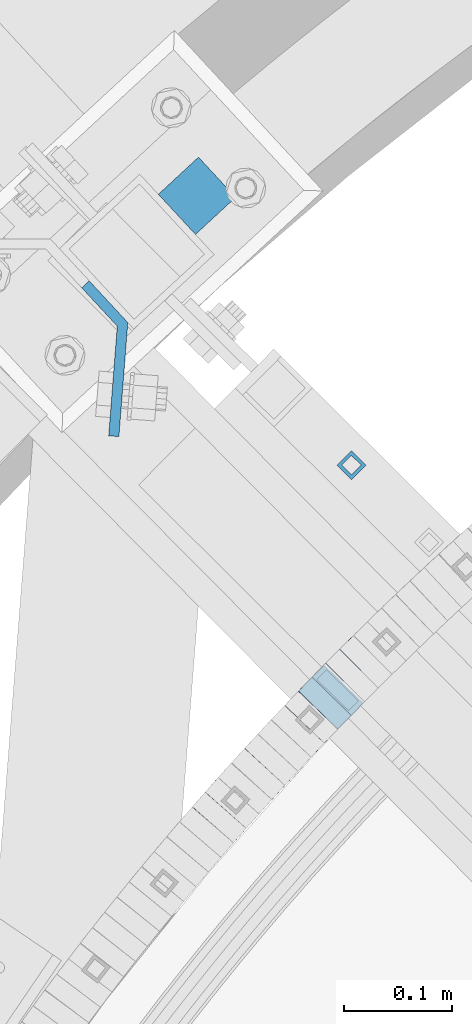
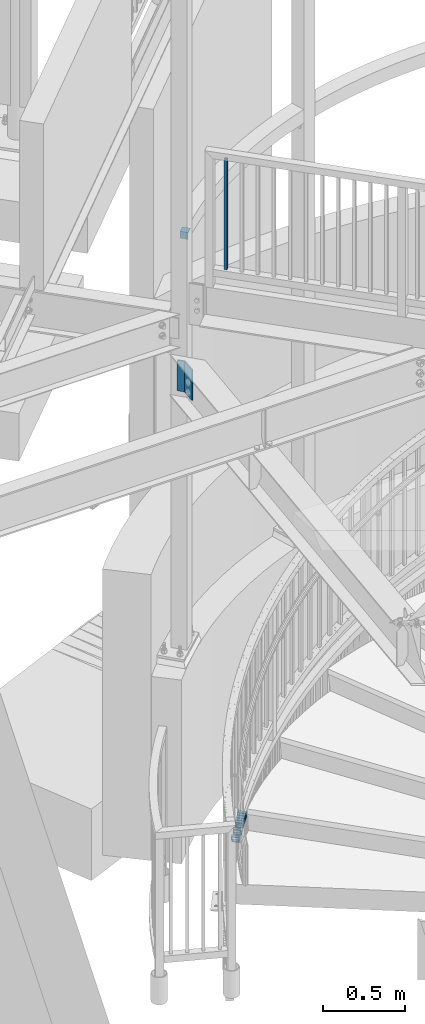
# One storey, part 484 of 975: 10 beams.
"""IFC2X3 building model written with IfcOpenShell, lengths in millimetres."""

from ifc_helpers import new_model, si_unit, frame, origin_with_axes, place, context, subcontext, project, spatial, faceted_brep, material, type_object, element, save


model = new_model("IFC2X3")

# Units and contexts
model_context = context("Model", 3, precision=1e-05, world=origin_with_axes())
body_context = subcontext(model_context, "Body", "Model", "MODEL_VIEW")
ifc_project = project(units=[si_unit("LENGTHUNIT", "METRE", prefix="MILLI"), si_unit("AREAUNIT", "SQUARE_METRE"), si_unit("VOLUMEUNIT", "CUBIC_METRE"), si_unit("MASSUNIT", "GRAM", prefix="KILO"), si_unit("TIMEUNIT", "SECOND"), si_unit("PLANEANGLEUNIT", "RADIAN"), si_unit("SOLIDANGLEUNIT", "STERADIAN"), si_unit("THERMODYNAMICTEMPERATUREUNIT", "DEGREE_CELSIUS"), si_unit("LUMINOUSINTENSITYUNIT", "LUMEN")], contexts=[model_context])

# Site, building, storey
site_placement = place(None, origin_with_axes())
site = spatial("IfcSite", under=ifc_project, at=site_placement, CompositionType="ELEMENT")
building_placement = place(site_placement, origin_with_axes())
building = spatial("IfcBuilding", under=site, at=building_placement, Name="Undefined", CompositionType="ELEMENT")
storey_placement = place(building_placement, origin_with_axes())
storey = spatial("IfcBuildingStorey", under=building, at=storey_placement, Name="Undefined", CompositionType="ELEMENT", Elevation=0.0)

# Beams
ifc_material_1 = material()
beam_type_1 = type_object("IfcBeamType", Name="HSS3/4X3/4X.120_TUBES", PredefinedType="NOTDEFINED")
beam_1_placement = place(storey_placement, frame((32697.1414004107, 5621.60406811201, 4279.9), z_axis=(-0.708992011834517, 0.705216510835392, 0.0), x_axis=(0.0, 0.0, 1.0)))
element("IfcBeam", 1, at=beam_1_placement, inside=storey, type_object=beam_type_1, material=ifc_material_1, Name="PICKET", ObjectType="HSS3/4X3/4X.120_TUBES", context=body_context, shape_type="Brep", body=[
    faceted_brep([(0.0, 6.34999999998763, -6.34999999998763), (0.0, -6.35000000000582, -6.34999999998763), (825.49997943247, -6.35000000000582, -6.34999999998763), (825.49997943247, 6.34999999998763, -6.34999999998763), (0.0, -6.34999999998763, 6.34999999998763), (825.49997943247, -6.34999999998763, 6.34999999998763), (0.0, 6.35000000000946, 6.34999999998763), (825.49997943247, 6.35000000000946, 6.34999999998763), (0.0, 9.52499999997963, -9.52499999997963), (0.0, 9.52500000000873, 9.5249999999869), (825.49997943247, 9.52500000000873, 9.5249999999869), (825.49997943247, 9.52499999997963, -9.52499999997963), (0.0, -9.52499999997963, 9.52499999998327), (825.49997943247, -9.52499999997963, 9.52499999998327), (0.0, -9.52500000000873, -9.5249999999869), (825.49997943247, -9.52500000000873, -9.5249999999869)], [[[0, 1, 2, 3]], [[1, 4, 5, 2]], [[4, 6, 7, 5]], [[6, 0, 3, 7]], [[8, 9, 10, 11]], [[9, 12, 13, 10]], [[12, 14, 15, 13]], [[14, 8, 11, 15]], [[13, 15, 11, 10], [5, 7, 3, 2]], [[14, 12, 9, 8], [6, 4, 1, 0]]]),
])
beam_type_2 = type_object("IfcBeamType", Name="HSS2X2X.188_TUBES", PredefinedType="NOTDEFINED")
beam_2_placement = place(storey_placement, frame((32709.6480122924, 5438.25102614261, 325.589963452377), z_axis=(0.707106781186513, -0.707106781186582, 3.1377567211166e-14), x_axis=(-0.673979567924122, -0.673979567924025, -0.302494766965906)))
element("IfcBeam", 2, at=beam_2_placement, inside=storey, type_object=beam_type_2, material=ifc_material_1, Name="WALL", ObjectType="HSS2X2X.188_TUBES", context=body_context, shape_type="Brep", body=[
    faceted_brep([(0.0, 20.6374999999753, -20.6375000000298), (0.0, -20.6375000000153, -20.6375000000153), (18.8433011969464, -20.6374999999898, -20.6375000000226), (18.8433011969719, 20.6375000000007, -20.6374999999862), (0.0, -20.6374999999825, 20.6375000000335), (18.8433011969828, -20.6375000000044, 20.6375000000189), (0.0, 20.6375000000116, 20.6375000000189), (18.8433011970155, 20.6374999999862, 20.6375000000517), (0.0, 25.3999999999724, -25.4000000000342), (0.0, 25.400000000016, 25.4000000000196), (18.8433011970228, 25.3999999999833, 25.4000000000597), (18.8433011969719, 25.4000000000015, -25.3999999999869), (0.0, -25.399999999976, 25.4000000000378), (18.8433011969864, -25.4000000000051, 25.4000000000196), (0.0, -25.400000000016, -25.4000000000196), (18.8433011969391, -25.3999999999869, -25.4000000000269)], [[[0, 1, 2, 3]], [[1, 4, 5, 2]], [[4, 6, 7, 5]], [[6, 0, 3, 7]], [[8, 9, 10, 11]], [[9, 12, 13, 10]], [[12, 14, 15, 13]], [[14, 8, 11, 15]], [[13, 15, 11, 10], [5, 7, 3, 2]], [[14, 12, 9, 8], [6, 4, 1, 0]]]),
])
beam_3_placement = place(storey_placement, frame((32696.6904416924, 5425.42022046742, 319.898575306206), z_axis=(0.715441150794838, -0.698672999155798, -8.11802465250365e-11), x_axis=(-0.665704015149498, -0.681680911153189, -0.303561031068211)))
element("IfcBeam", 3, at=beam_3_placement, inside=storey, type_object=beam_type_2, material=ifc_material_1, Name="WALL", ObjectType="HSS2X2X.188_TUBES", context=body_context, shape_type="Brep", body=[
    faceted_brep([(0.0, 20.6374999999753, -20.6375000000298), (0.0, -20.6375000000153, -20.6375000000153), (18.7771137292038, -20.637500000008, -20.6374999999862), (18.777113729182, 20.6375000000062, -20.6375000000189), (0.0, -20.6374999999825, 20.6375000000335), (18.7771137291729, -20.6374999999916, 20.6374999999753), (0.0, 20.6375000000116, 20.6375000000189), (18.7771137291529, 20.6375000000207, 20.6374999999389), (0.0, 25.3999999999724, -25.4000000000342), (0.0, 25.400000000016, 25.4000000000196), (18.7771137291475, 25.4000000000251, 25.3999999999287), (18.7771137291857, 25.4000000000051, -25.4000000000196), (0.0, -25.399999999976, 25.4000000000378), (18.7771137291711, -25.3999999999905, 25.3999999999724), (0.0, -25.400000000016, -25.4000000000196), (18.7771137292129, -25.4000000000124, -25.3999999999724)], [[[0, 1, 2, 3]], [[1, 4, 5, 2]], [[4, 6, 7, 5]], [[6, 0, 3, 7]], [[8, 9, 10, 11]], [[9, 12, 13, 10]], [[12, 14, 15, 13]], [[14, 8, 11, 15]], [[13, 15, 11, 10], [5, 7, 3, 2]], [[14, 12, 9, 8], [6, 4, 1, 0]]]),
])
beam_4_placement = place(storey_placement, frame((32684.2760341581, 5412.70786715233, 314.2379475618), z_axis=(0.715441150794838, -0.698672999155798, -8.11802465250365e-11), x_axis=(-0.664621009862544, -0.680571913859332, -0.308384148936255)))
element("IfcBeam", 4, at=beam_4_placement, inside=storey, type_object=beam_type_2, material=ifc_material_1, Name="WALL", ObjectType="HSS2X2X.188_TUBES", context=body_context, shape_type="Brep", body=[
    faceted_brep([(0.0, 20.6374999999753, -20.6375000000298), (0.0, -20.6375000000153, -20.6375000000153), (18.8066477608099, -20.6374999999862, -20.6375000000116), (18.8066477608172, 20.6375000000062, -20.6374999999971), (0.0, -20.6374999999825, 20.6375000000335), (18.8066477608463, -20.6375000000062, 20.6375000000407), (0.0, 20.6375000000116, 20.6375000000189), (18.8066477608536, 20.6374999999844, 20.637500000048), (0.0, 25.3999999999724, -25.4000000000342), (0.0, 25.400000000016, 25.4000000000196), (18.8066477608591, 25.3999999999814, 25.400000000056), (18.8066477608154, 25.4000000000051, -25.4000000000015), (0.0, -25.399999999976, 25.4000000000378), (18.8066477608518, -25.4000000000087, 25.4000000000451), (0.0, -25.400000000016, -25.4000000000196), (18.8066477608081, -25.3999999999851, -25.4000000000196)], [[[0, 1, 2, 3]], [[1, 4, 5, 2]], [[4, 6, 7, 5]], [[6, 0, 3, 7]], [[8, 9, 10, 11]], [[9, 12, 13, 10]], [[12, 14, 15, 13]], [[14, 8, 11, 15]], [[13, 15, 11, 10], [5, 7, 3, 2]], [[14, 12, 9, 8], [6, 4, 1, 0]]]),
])
beam_5_placement = place(storey_placement, frame((32671.3977147235, 5399.64724950157, 308.389345705644), z_axis=(0.723608232244992, -0.690210928794435, 1.00843806194462e-10), x_axis=(-0.657892055054821, -0.689725542057486, -0.302418122025204)))
element("IfcBeam", 5, at=beam_5_placement, inside=storey, type_object=beam_type_2, material=ifc_material_1, Name="WALL", ObjectType="HSS2X2X.188_TUBES", context=body_context, shape_type="Brep", body=[
    faceted_brep([(0.0, 20.6374999999753, -20.6375000000298), (0.0, -20.6375000000153, -20.6375000000153), (18.8480768248774, -20.6374999999716, -20.6375000000735), (18.8480768249356, 20.6375000000153, -20.6375000000226), (0.0, -20.6374999999825, 20.6375000000335), (18.8480768249283, -20.6374999999935, 20.6374999999716), (0.0, 20.6375000000116, 20.6375000000189), (18.8480768249865, 20.6374999999935, 20.6375000000262), (0.0, 25.3999999999724, -25.4000000000342), (0.0, 25.400000000016, 25.4000000000196), (18.848076825001, 25.3999999999887, 25.4000000000378), (18.8480768249392, 25.4000000000142, -25.4000000000233), (0.0, -25.399999999976, 25.4000000000378), (18.8480768249283, -25.399999999996, 25.3999999999833), (0.0, -25.400000000016, -25.4000000000196), (18.8480768248664, -25.3999999999687, -25.4000000000779)], [[[0, 1, 2, 3]], [[1, 4, 5, 2]], [[4, 6, 7, 5]], [[6, 0, 3, 7]], [[8, 9, 10, 11]], [[9, 12, 13, 10]], [[12, 14, 15, 13]], [[14, 8, 11, 15]], [[13, 15, 11, 10], [5, 7, 3, 2]], [[14, 12, 9, 8], [6, 4, 1, 0]]]),
])
beam_6_placement = place(storey_placement, frame((32659.0070910159, 5386.70265124124, 302.737230108235), z_axis=(0.726393020279012, -0.687279550175862, 2.07463699553046e-11), x_axis=(-0.653802268984227, -0.691010527983261, -0.308297004992542)))
element("IfcBeam", 6, at=beam_6_placement, inside=storey, type_object=beam_type_2, material=ifc_material_1, Name="WALL", ObjectType="HSS2X2X.188_TUBES", context=body_context, shape_type="Brep", body=[
    faceted_brep([(0.0, 20.6374999999753, -20.6375000000298), (0.0, -20.6375000000153, -20.6375000000153), (18.8066477608099, -20.6374999999862, -20.6375000000116), (18.8066477608172, 20.6375000000062, -20.6374999999971), (0.0, -20.6374999999825, 20.6375000000335), (18.8066477608463, -20.6375000000062, 20.6375000000407), (0.0, 20.6375000000116, 20.6375000000189), (18.8066477608536, 20.6374999999844, 20.637500000048), (0.0, 25.3999999999724, -25.4000000000342), (0.0, 25.400000000016, 25.4000000000196), (18.8066477608591, 25.3999999999814, 25.400000000056), (18.8066477608154, 25.4000000000051, -25.4000000000015), (0.0, -25.399999999976, 25.4000000000378), (18.8066477608518, -25.4000000000087, 25.4000000000451), (0.0, -25.400000000016, -25.4000000000196), (18.8066477608081, -25.3999999999851, -25.4000000000196)], [[[0, 1, 2, 3]], [[1, 4, 5, 2]], [[4, 6, 7, 5]], [[6, 0, 3, 7]], [[8, 9, 10, 11]], [[9, 12, 13, 10]], [[12, 14, 15, 13]], [[14, 8, 11, 15]], [[13, 15, 11, 10], [5, 7, 3, 2]], [[14, 12, 9, 8], [6, 4, 1, 0]]]),
])
beam_7_placement = place(storey_placement, frame((32622.0405859042, 5347.29049031292, 285.535940786572), z_axis=(0.737154140605314, -0.675724628075994, 3.47016168689151e-10), x_axis=(-0.642844486019819, -0.701284894021664, -0.308140332009522)))
element("IfcBeam", 7, at=beam_7_placement, inside=storey, type_object=beam_type_2, material=ifc_material_1, Name="WALL", ObjectType="HSS2X2X.188_TUBES", context=body_context, shape_type="Brep", body=[
    faceted_brep([(0.0, 20.6374999999753, -20.6375000000298), (0.0, -20.6375000000153, -20.6375000000153), (18.8225928075335, -20.6374999999935, -20.6375000000298), (18.8225928075699, 20.6374999999898, -20.6374999999825), (0.0, -20.6374999999825, 20.6375000000335), (18.8225928075772, -20.637500000008, 20.6375000000226), (0.0, 20.6375000000116, 20.6375000000189), (18.8225928076135, 20.6374999999753, 20.6375000000698), (0.0, 25.3999999999724, -25.4000000000342), (0.0, 25.400000000016, 25.4000000000196), (18.8225928076281, 25.3999999999705, 25.4000000000815), (18.8225928075663, 25.3999999999905, -25.3999999999796), (0.0, -25.399999999976, 25.4000000000378), (18.8225928075808, -25.4000000000087, 25.4000000000233), (0.0, -25.400000000016, -25.4000000000196), (18.8225928075226, -25.3999999999905, -25.4000000000378)], [[[0, 1, 2, 3]], [[1, 4, 5, 2]], [[4, 6, 7, 5]], [[6, 0, 3, 7]], [[8, 9, 10, 11]], [[9, 12, 13, 10]], [[12, 14, 15, 13]], [[14, 8, 11, 15]], [[13, 15, 11, 10], [5, 7, 3, 2]], [[14, 12, 9, 8], [6, 4, 1, 0]]]),
])
beam_8_placement = place(storey_placement, frame((32585.5961167132, 5307.15950885067, 268.332942800624), z_axis=(0.752922081455558, -0.658109671146557, 6.12868120697384e-11), x_axis=(-0.626164333835291, -0.716374449811682, -0.307775688919083)))
element("IfcBeam", 8, at=beam_8_placement, inside=storey, type_object=beam_type_2, material=ifc_material_1, Name="WALL", ObjectType="HSS2X2X.188_TUBES", context=body_context, shape_type="Brep", body=[
    faceted_brep([(0.0, 20.6374999999753, -20.6375000000298), (0.0, -20.6375000000153, -20.6375000000153), (18.8433011969464, -20.6374999999898, -20.6375000000226), (18.8433011969719, 20.6375000000007, -20.6374999999862), (0.0, -20.6374999999825, 20.6375000000335), (18.8433011969828, -20.6375000000044, 20.6375000000189), (0.0, 20.6375000000116, 20.6375000000189), (18.8433011970155, 20.6374999999862, 20.6375000000517), (0.0, 25.3999999999724, -25.4000000000342), (0.0, 25.400000000016, 25.4000000000196), (18.8433011970228, 25.3999999999833, 25.4000000000597), (18.8433011969719, 25.4000000000015, -25.3999999999869), (0.0, -25.399999999976, 25.4000000000378), (18.8433011969864, -25.4000000000051, 25.4000000000196), (0.0, -25.400000000016, -25.4000000000196), (18.8433011969391, -25.3999999999869, -25.4000000000269)], [[[0, 1, 2, 3]], [[1, 4, 5, 2]], [[4, 6, 7, 5]], [[6, 0, 3, 7]], [[8, 9, 10, 11]], [[9, 12, 13, 10]], [[12, 14, 15, 13]], [[14, 8, 11, 15]], [[13, 15, 11, 10], [5, 7, 3, 2]], [[14, 12, 9, 8], [6, 4, 1, 0]]]),
])
ifc_material_2 = material(Name="STEEL/A36")
beam_type_3 = type_object("IfcBeamType", Name="L2X2X1/4", PredefinedType="NOTDEFINED")
beam_9_placement = place(storey_placement, frame((32571.0519669893, 5852.90155434527, 4445.0), z_axis=(0.733848438057782, 0.679313234053447, 0.0), x_axis=(-0.679313234053475, 0.733848438057757, 0.0)))
element("IfcBeam", 9, at=beam_9_placement, inside=storey, type_object=beam_type_3, material=ifc_material_2, Name="ANGLE", ObjectType="L2X2X1/4", context=body_context, shape_type="Brep", body=[
    faceted_brep([(0.0, 25.3999999999724, -25.4000000000342), (0.0, 25.400000000016, 25.4000000000196), (50.8000000000102, 25.3999999999996, 25.4000000000015), (50.7999999999411, 25.3999999999996, -25.4000000000487), (3.27418092638254e-11, 19.0500000000002, 25.4000000000269), (50.8000000000102, 19.0500000000002, 25.4000000000015), (-2.5465851649642e-11, 19.0500000000002, -19.0500000000211), (50.7999999999483, 19.0500000000002, -19.0500000000429), (-2.5465851649642e-11, -25.3999999999996, -19.0500000000211), (50.7999999999483, -25.3999999999996, -19.0500000000429), (0.0, -25.400000000016, -25.4000000000196), (50.7999999999411, -25.3999999999996, -25.4000000000487)], [[[0, 1, 2, 3]], [[1, 4, 5, 2]], [[4, 6, 7, 5]], [[6, 8, 9, 7]], [[8, 10, 11, 9]], [[10, 0, 3, 11]], [[5, 7, 9, 11, 3, 2]], [[10, 8, 6, 4, 1, 0]]]),
])
beam_type_4 = type_object("IfcBeamType", PredefinedType="NOTDEFINED")
beam_10_placement = place(storey_placement, frame((32450.2742844317, 5789.41098036274, 3473.45), z_axis=(0.0, 0.0, 1.0), x_axis=(0.679313234053469, -0.733848438057762, 0.0)))
element("IfcBeam", 10, at=beam_10_placement, inside=storey, type_object=beam_type_4, material=ifc_material_2, Name="BENT_PLATE", context=body_context, shape_type="Brep", body=[
    faceted_brep([(7.56699591875076e-08, -4.76250000000437, -114.3), (0.0, -4.76249999999982, 114.300003051758), (0.0, 4.76249999999982, 114.300003051758), (-7.56735971663147e-08, 4.76250000000437, -114.3), (52.7280773425846, 4.76250083786726, 114.3), (52.7280773425846, 4.76250083786726, -114.3), (48.5615351807755, -4.7624992283454, -114.3), (48.5615351807755, -4.7624992283454, 114.3), (124.80975480724, -73.2211331387662, 114.3), (124.80975480724, -73.2211331387662, -114.3), (117.815080203065, -79.6864368580027, 114.3), (117.815080203065, -79.6864368580027, -114.3)], [[[0, 1, 2, 3]], [[3, 2, 4, 5]], [[1, 0, 6, 7]], [[5, 4, 8, 9]], [[4, 2, 1, 7, 10, 8]], [[7, 6, 11, 10]], [[6, 0, 3, 5, 9, 11]], [[10, 11, 9, 8]]]),
])

save(model, "model.ifc")
